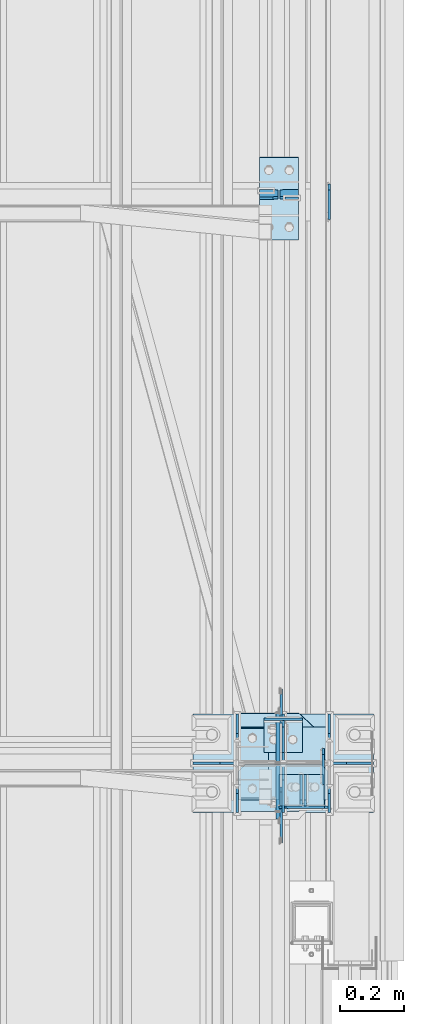
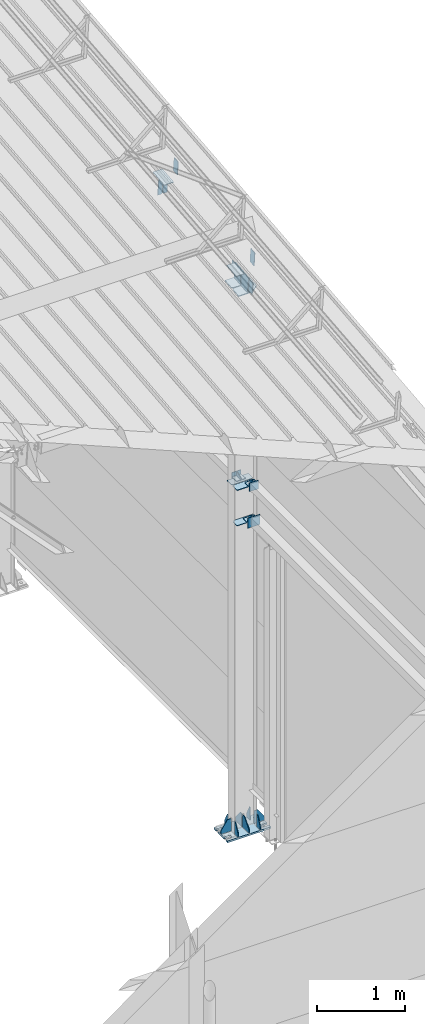
# One storey, part 156 of 709: 33 plates, 4 openings, 8 elements without a shape of their own.
"""IFC4 building model written with IfcOpenShell, lengths in millimetres."""

from ifc_helpers import new_model, si_unit, direction, frame, origin_with_axes, place, context, subcontext, project, spatial, line, arc, indexed_curve, outline, extrude, material, element, aggregate, save


model = new_model("IFC4")

# Units and contexts
model_context = context("Model", 3, precision=0.2, world=origin_with_axes(), true_north=direction((0.0, 1.0)))
body_context = subcontext(model_context, "Body", "Model", "MODEL_VIEW")
ifc_project = project(units=[si_unit("LENGTHUNIT", "METRE", prefix="MILLI"), si_unit("AREAUNIT", "SQUARE_METRE"), si_unit("VOLUMEUNIT", "CUBIC_METRE"), si_unit("MASSUNIT", "GRAM", prefix="KILO"), si_unit("TIMEUNIT", "SECOND"), si_unit("PLANEANGLEUNIT", "RADIAN"), si_unit("SOLIDANGLEUNIT", "STERADIAN"), si_unit("THERMODYNAMICTEMPERATUREUNIT", "DEGREE_CELSIUS"), si_unit("LUMINOUSINTENSITYUNIT", "LUMEN")], contexts=[model_context])

# Site, building, storey
site_placement = place(None, origin_with_axes())
site = spatial("IfcSite", under=ifc_project, at=site_placement, CompositionType="ELEMENT")
building_placement = place(site_placement, origin_with_axes())
building = spatial("IfcBuilding", under=site, at=building_placement, Name="Undefined", CompositionType="ELEMENT")
storey_placement = place(building_placement, origin_with_axes())
storey = spatial("IfcBuildingStorey", under=building, at=storey_placement, Name="Undefined", CompositionType="ELEMENT", Elevation=0.0)

# Assembly, plates, voiding features
assembly_1_placement = place(storey_placement, frame((49851.0, 5500.0, -200.0), z_axis=(0.0, -1.0, 0.0), x_axis=(0.0, 0.0, 1.0)))
assembly_1 = element("IfcElementAssembly", 1, at=assembly_1_placement, inside=storey)
ifc_material = material(Name="C355-6", Category="STEEL")
plate_1_placement = place(assembly_1_placement, frame((4802.0, -140.0, -114.5), z_axis=(-1.0, 0.0, 0.0), x_axis=(0.0, 0.0, 1.0)))
plate_1 = element("IfcPlate", 2, at=plate_1_placement, material=ifc_material, ObjectType="529", context=body_context, shape_type="SolidModel", body=[
    extrude(outline(indexed_curve([(0.0, 0.0), (95.75, 0.0), (110.75, 15.0), (110.75, 265.0), (95.75, 280.0), (0.0, 280.0)], segments=[line(1, 2, 3, 4, 5, 6, 1)])), frame((0.0, 0.0, 4.0), z_axis=(0.0, 0.0, 1.0), x_axis=(1.0, 0.0, 0.0)), (0.0, 0.0, -1.0), 8.0),
])
plate_2_placement = place(assembly_1_placement, frame((4312.0, -140.0, 23.75), z_axis=(1.0, 0.0, 0.0), x_axis=(0.0, 0.7071067812, -0.7071067812)))
plate_2 = element("IfcPlate", 3, at=plate_2_placement, material=ifc_material, Name="PLATE", ObjectType="532", context=body_context, shape_type="SolidModel", body=[
    extrude(outline(indexed_curve([(0.0, 0.0), (28.28427, 0.0), (197.9899, 169.70563), (197.9899, 197.9899), (133.81996, 262.15984), (-64.16994, 64.16994)], segments=[line(1, 2, 3, 4, 5, 6, 1)])), frame((0.0, 0.0, 4.0), z_axis=(0.0, 0.0, 1.0), x_axis=(1.0, 0.0, 0.0)), (0.0, 0.0, -1.0), 8.0),
])
plate_3_placement = place(assembly_1_placement, frame((4802.0, 140.0, 114.5), z_axis=(-1.0, 0.0, 0.0), x_axis=(0.0, 0.0, -1.0)))
plate_3 = element("IfcPlate", 4, at=plate_3_placement, material=ifc_material, ObjectType="505", context=body_context, shape_type="SolidModel", body=[
    extrude(outline(indexed_curve([(0.0, 0.0), (95.75, 0.0), (110.75, 15.0), (110.75, 265.0), (95.75, 280.0), (0.0, 280.0)], segments=[line(1, 2, 3, 4, 5, 6, 1)])), frame((0.0, 0.0, 4.0), z_axis=(0.0, 0.0, 1.0), x_axis=(1.0, 0.0, 0.0)), (0.0, 0.0, -1.0), 8.0),
])
plate_4_placement = place(assembly_1_placement, frame((7533.21454, 17.0, 4.74007), z_axis=(0.0, 1.0, 0.0), x_axis=(-0.099503719, 0.0, 0.9950371902)))
plate_4 = element("IfcPlate", 5, at=plate_4_placement, material=ifc_material, ObjectType="465", context=body_context, shape_type="SolidModel", body=[
    extrude(outline(indexed_curve([(0.0, 0.0), (145.70786, 0.0), (148.29495, 222.12903), (-24.97066, 222.06948)], segments=[line(1, 2, 3, 4, 1)])), frame((0.0, 0.0, 6.0), z_axis=(0.0, 0.0, 1.0), x_axis=(1.0, 0.0, 0.0)), (0.0, 0.0, -1.0), 12.0),
])
plate_5_placement = place(assembly_1_placement, frame((7526.28426, 139.0, 4.34206), z_axis=(0.9950371902, 0.0, 0.099503719), x_axis=(-0.099503719, 0.0, 0.9950371902)))
plate_5 = element("IfcPlate", 6, at=plate_5_placement, material=ifc_material, ObjectType="464", context=body_context, shape_type="SolidModel", body=[
    extrude(outline(indexed_curve([(0.0, 15.0), (15.0, 0.0), (146.70786, 0.0), (146.70786, 187.5), (73.5, 278.0), (15.0, 278.0), (0.0, 263.0)], segments=[line(1, 2, 3, 4, 5, 6, 7, 1)])), frame((0.0, 0.0, 6.0), z_axis=(0.0, 0.0, 1.0), x_axis=(1.0, 0.0, 0.0)), (0.0, 0.0, -1.0), 12.0),
])
plate_6_placement = place(assembly_1_placement, frame((12.5, -284.0, 155.0), z_axis=(1.0, 0.0, 0.0), x_axis=(0.0, 0.0, -1.0)))
plate_6 = element("IfcPlate", 7, at=plate_6_placement, material=ifc_material, ObjectType="425", context=body_context, shape_type="SolidModel", body=[
    extrude(outline(indexed_curve([(0.0, 0.0), (310.0, 0.0), (310.0, 568.0), (0.0, 568.0)], segments=[line(1, 2, 3, 4, 1)])), frame((0.0, 0.0, 12.5), z_axis=(0.0, 0.0, 1.0), x_axis=(1.0, 0.0, 0.0)), (0.0, 0.0, -1.0), 25.0),
])
voiding_feature_1_placement = place(plate_6_placement, frame((40.0, 568.0, 0.0), z_axis=(0.0, 0.0, -1.0), x_axis=(1.0, 0.0, 0.0)))
element("IfcVoidingFeature", 8, at=voiding_feature_1_placement, cuts=plate_6, PredefinedType="HOLE", context=body_context, shape_type="SolidModel", body=[
    extrude(outline(indexed_curve([(0.0, 0.0), (50.0, 0.0), (50.0, 60.0), (42.67767, 77.67767), (25.0, 85.0), (25.0, 85.0), (7.32233, 77.67767), (0.0, 60.0)], segments=[line(1, 2, 3), arc(3, 4, 5), line(5, 6), arc(6, 7, 8), line(8, 1)])), frame((0.0, 0.0, 12.5), z_axis=(0.0, 0.0, 1.0), x_axis=(1.0, 0.0, 0.0)), (0.0, 0.0, -1.0), 25.0),
])
voiding_feature_2_placement = place(plate_6_placement, frame((40.0, 0.0, 0.0), z_axis=(0.0, 0.0, 1.0), x_axis=(1.0, 0.0, 0.0)))
element("IfcVoidingFeature", 9, at=voiding_feature_2_placement, cuts=plate_6, PredefinedType="HOLE", context=body_context, shape_type="SolidModel", body=[
    extrude(outline(indexed_curve([(0.0, 0.0), (50.0, 0.0), (50.0, 60.0), (42.67767, 77.67767), (25.0, 85.0), (25.0, 85.0), (7.32233, 77.67767), (0.0, 60.0)], segments=[line(1, 2, 3), arc(3, 4, 5), line(5, 6), arc(6, 7, 8), line(8, 1)])), frame((0.0, 0.0, 12.5), z_axis=(0.0, 0.0, 1.0), x_axis=(1.0, 0.0, 0.0)), (0.0, 0.0, -1.0), 25.0),
])
voiding_feature_3_placement = place(plate_6_placement, frame((270.0, 568.0, 0.0), z_axis=(0.0, 0.0, 1.0), x_axis=(-1.0, 0.0, 0.0)))
element("IfcVoidingFeature", 10, at=voiding_feature_3_placement, cuts=plate_6, PredefinedType="HOLE", context=body_context, shape_type="SolidModel", body=[
    extrude(outline(indexed_curve([(0.0, 0.0), (50.0, 0.0), (50.0, 60.0), (42.67767, 77.67767), (25.0, 85.0), (25.0, 85.0), (7.32233, 77.67767), (0.0, 60.0)], segments=[line(1, 2, 3), arc(3, 4, 5), line(5, 6), arc(6, 7, 8), line(8, 1)])), frame((0.0, 0.0, 12.5), z_axis=(0.0, 0.0, 1.0), x_axis=(1.0, 0.0, 0.0)), (0.0, 0.0, -1.0), 25.0),
])
voiding_feature_4_placement = place(plate_6_placement, frame((270.0, 0.0, 0.0), z_axis=(0.0, 0.0, -1.0), x_axis=(-1.0, 0.0, 0.0)))
element("IfcVoidingFeature", 11, at=voiding_feature_4_placement, cuts=plate_6, PredefinedType="HOLE", context=body_context, shape_type="SolidModel", body=[
    extrude(outline(indexed_curve([(0.0, 0.0), (50.0, 0.0), (50.0, 60.0), (42.67767, 77.67767), (25.0, 85.0), (25.0, 85.0), (7.32233, 77.67767), (0.0, 60.0)], segments=[line(1, 2, 3), arc(3, 4, 5), line(5, 6), arc(6, 7, 8), line(8, 1)])), frame((0.0, 0.0, 12.5), z_axis=(0.0, 0.0, 1.0), x_axis=(1.0, 0.0, 0.0)), (0.0, 0.0, -1.0), 25.0),
])
plate_7_placement = place(assembly_1_placement, frame((25.0, -149.0, 0.0), z_axis=(0.0, 0.0, 1.0), x_axis=(0.0, -1.0, 0.0)))
plate_7 = element("IfcPlate", 12, at=plate_7_placement, material=ifc_material, ObjectType="418", context=body_context, shape_type="SolidModel", body=[
    extrude(outline(indexed_curve([(0.0, 0.0), (135.0, 0.0), (135.0, 50.0), (50.0, 175.0), (0.0, 175.0)], segments=[line(1, 2, 3, 4, 5, 1)])), frame((0.0, 0.0, 4.0), z_axis=(0.0, 0.0, 1.0), x_axis=(1.0, 0.0, 0.0)), (0.0, 0.0, -1.0), 8.0),
])
plate_8_placement = place(assembly_1_placement, frame((25.0, 0.0, -2.75), z_axis=(0.0, -1.0, 0.0), x_axis=(0.0, 0.0, -1.0)))
plate_8 = element("IfcPlate", 13, at=plate_8_placement, material=ifc_material, ObjectType="417", context=body_context, shape_type="SolidModel", body=[
    extrude(outline(indexed_curve([(0.0, 0.0), (152.25, 0.0), (152.25, 50.0), (50.0, 175.0), (0.0, 175.0)], segments=[line(1, 2, 3, 4, 5, 1)])), frame((0.0, 0.0, 4.0), z_axis=(0.0, 0.0, 1.0), x_axis=(1.0, 0.0, 0.0)), (0.0, 0.0, -1.0), 8.0),
])
plate_9_placement = place(assembly_1_placement, frame((25.0, 145.0, -74.5), z_axis=(0.0, -1.0, 0.0), x_axis=(0.0, 0.0, -1.0)))
plate_9 = element("IfcPlate", 14, at=plate_9_placement, material=ifc_material, ObjectType="426", context=body_context, shape_type="SolidModel", body=[
    extrude(outline(indexed_curve([(0.0, 0.0), (80.5, 0.0), (80.5, 50.0), (20.0, 175.0), (0.0, 175.0)], segments=[line(1, 2, 3, 4, 5, 1)])), frame((0.0, 0.0, 4.0), z_axis=(0.0, 0.0, 1.0), x_axis=(1.0, 0.0, 0.0)), (0.0, 0.0, -1.0), 8.0),
])
plate_10_placement = place(assembly_1_placement, frame((25.0, -145.0, -74.5), z_axis=(0.0, -1.0, 0.0), x_axis=(0.0, 0.0, -1.0)))
plate_10 = element("IfcPlate", 15, at=plate_10_placement, material=ifc_material, ObjectType="426", context=body_context, shape_type="SolidModel", body=[
    extrude(outline(indexed_curve([(0.0, 0.0), (80.5, 0.0), (80.5, 50.0), (20.0, 175.0), (0.0, 175.0)], segments=[line(1, 2, 3, 4, 5, 1)])), frame((0.0, 0.0, 4.0), z_axis=(0.0, 0.0, 1.0), x_axis=(1.0, 0.0, 0.0)), (0.0, 0.0, -1.0), 8.0),
])
plate_11_placement = place(assembly_1_placement, frame((25.0, 145.0, 74.5), z_axis=(0.0, 1.0, 0.0), x_axis=(0.0, 0.0, 1.0)))
plate_11 = element("IfcPlate", 16, at=plate_11_placement, material=ifc_material, ObjectType="426", context=body_context, shape_type="SolidModel", body=[
    extrude(outline(indexed_curve([(0.0, 0.0), (80.5, 0.0), (80.5, 50.0), (20.0, 175.0), (0.0, 175.0)], segments=[line(1, 2, 3, 4, 5, 1)])), frame((0.0, 0.0, 4.0), z_axis=(0.0, 0.0, 1.0), x_axis=(1.0, 0.0, 0.0)), (0.0, 0.0, -1.0), 8.0),
])
plate_12_placement = place(assembly_1_placement, frame((25.0, 0.0, 2.75), z_axis=(0.0, 1.0, 0.0), x_axis=(0.0, 0.0, 1.0)))
plate_12 = element("IfcPlate", 17, at=plate_12_placement, material=ifc_material, ObjectType="417", context=body_context, shape_type="SolidModel", body=[
    extrude(outline(indexed_curve([(0.0, 0.0), (152.25, 0.0), (152.25, 50.0), (50.0, 175.0), (0.0, 175.0)], segments=[line(1, 2, 3, 4, 5, 1)])), frame((0.0, 0.0, 4.0), z_axis=(0.0, 0.0, 1.0), x_axis=(1.0, 0.0, 0.0)), (0.0, 0.0, -1.0), 8.0),
])
plate_13_placement = place(assembly_1_placement, frame((25.0, 149.0, 0.0), z_axis=(0.0, 0.0, -1.0), x_axis=(0.0, 1.0, 0.0)))
plate_13 = element("IfcPlate", 18, at=plate_13_placement, material=ifc_material, ObjectType="418", context=body_context, shape_type="SolidModel", body=[
    extrude(outline(indexed_curve([(0.0, 0.0), (135.0, 0.0), (135.0, 50.0), (50.0, 175.0), (0.0, 175.0)], segments=[line(1, 2, 3, 4, 5, 1)])), frame((0.0, 0.0, 4.0), z_axis=(0.0, 0.0, 1.0), x_axis=(1.0, 0.0, 0.0)), (0.0, 0.0, -1.0), 8.0),
])
plate_14_placement = place(assembly_1_placement, frame((25.0, -145.0, 74.5), z_axis=(0.0, 1.0, 0.0), x_axis=(0.0, 0.0, 1.0)))
plate_14 = element("IfcPlate", 19, at=plate_14_placement, material=ifc_material, ObjectType="426", context=body_context, shape_type="SolidModel", body=[
    extrude(outline(indexed_curve([(0.0, 0.0), (80.5, 0.0), (80.5, 50.0), (20.0, 175.0), (0.0, 175.0)], segments=[line(1, 2, 3, 4, 5, 1)])), frame((0.0, 0.0, 4.0), z_axis=(0.0, 0.0, 1.0), x_axis=(1.0, 0.0, 0.0)), (0.0, 0.0, -1.0), 8.0),
])
plate_15_placement = place(assembly_1_placement, frame((7533.96354, 17.0, -2.75), z_axis=(0.0, -1.0, 0.0), x_axis=(0.099503719, 0.0, -0.9950371902)))
plate_15 = element("IfcPlate", 20, at=plate_15_placement, material=ifc_material, ObjectType="468", context=body_context, shape_type="SolidModel", body=[
    extrude(outline(indexed_curve([(0.0, 0.0), (156.50786, 0.0), (153.92076, 222.12903), (21.44323, 222.06948)], segments=[line(1, 2, 3, 4, 1)])), frame((0.0, 0.0, 6.0), z_axis=(0.0, 0.0, 1.0), x_axis=(1.0, 0.0, 0.0)), (0.0, 0.0, -1.0), 12.0),
])
plate_16_placement = place(assembly_1_placement, frame((7527.03327, 139.0, -3.14801), z_axis=(-0.9950371902, 0.0, -0.099503719), x_axis=(0.099503719, 0.0, -0.9950371902)))
plate_16 = element("IfcPlate", 21, at=plate_16_placement, material=ifc_material, ObjectType="467", context=body_context, shape_type="SolidModel", body=[
    extrude(outline(indexed_curve([(-0.10791, 14.99961), (15.0, 0.0), (155.50786, 0.0), (155.50786, 187.5), (71.5, 278.0), (13.0, 278.0), (-1.89209, 263.00039)], segments=[line(1, 2, 3, 4, 5, 6, 7, 1)])), frame((0.0, 0.0, 6.0), z_axis=(0.0, 0.0, 1.0), x_axis=(1.0, 0.0, 0.0)), (0.0, 0.0, -1.0), 12.0),
])
aggregate(assembly_1, [plate_1, plate_2, plate_3, plate_4, plate_5, plate_6, plate_7, plate_8, plate_9, plate_10, plate_11, plate_12, plate_13, plate_14, plate_15, plate_16])

# Assembly, plate
assembly_2_placement = place(storey_placement, frame((49837.5, 346.0, 6929.907), z_axis=(1.0, 0.0, 0.0), x_axis=(0.0, 0.9950371902, 0.099503719)))
assembly_2 = element("IfcElementAssembly", 22, at=assembly_2_placement, inside=storey)
plate_17_placement = place(assembly_2_placement, frame((5096.83432, -80.0, 6.5), z_axis=(0.0, 0.0, 1.0), x_axis=(0.0, 1.0, 0.0)))
plate_17 = element("IfcPlate", 23, at=plate_17_placement, material=ifc_material, ObjectType="463", context=body_context, shape_type="SolidModel", body=[
    extrude(outline(indexed_curve([(0.0, 0.0), (160.0, 0.0), (160.0, 160.0), (0.0, 160.0)], segments=[line(1, 2, 3, 4, 1)])), frame((0.0, 0.0, 4.0), z_axis=(0.0, 0.0, 1.0), x_axis=(1.0, 0.0, 0.0)), (0.0, 0.0, -1.0), 8.0),
])
aggregate(assembly_2, [plate_17])

# Assembly, plates
assembly_3_placement = place(storey_placement, frame((49837.5, 5500.0, 7445.307), z_axis=(1.0, 0.0, 0.0), x_axis=(0.0, 0.9950371902, 0.099503719)))
assembly_3 = element("IfcElementAssembly", 24, at=assembly_3_placement, inside=storey)
plate_18_placement = place(assembly_3_placement, frame((1795.34469, 115.0, 62.0), z_axis=(-1.0, 0.0, 0.0), x_axis=(0.0, 0.0, -1.0)))
plate_18 = element("IfcPlate", 25, at=plate_18_placement, material=ifc_material, ObjectType="594", context=body_context, shape_type="SolidModel", body=[
    extrude(outline(indexed_curve([(0.0, 0.0), (43.5, 0.0), (58.5, 15.0), (58.5, 215.0), (43.5, 230.0), (0.0, 230.0)], segments=[line(1, 2, 3, 4, 5, 6, 1)])), frame((0.0, 0.0, 4.0), z_axis=(0.0, 0.0, 1.0), x_axis=(1.0, 0.0, 0.0)), (0.0, 0.0, -1.0), 8.0),
])
plate_19_placement = place(assembly_3_placement, frame((1795.34469, -115.0, -62.0), z_axis=(-1.0, 0.0, 0.0), x_axis=(0.0, 0.0, 1.0)))
plate_19 = element("IfcPlate", 26, at=plate_19_placement, material=ifc_material, ObjectType="594", context=body_context, shape_type="SolidModel", body=[
    extrude(outline(indexed_curve([(0.0, 0.0), (43.5, 0.0), (58.5, 15.0), (58.5, 215.0), (43.5, 230.0), (0.0, 230.0)], segments=[line(1, 2, 3, 4, 5, 6, 1)])), frame((0.0, 0.0, 4.0), z_axis=(0.0, 0.0, 1.0), x_axis=(1.0, 0.0, 0.0)), (0.0, 0.0, -1.0), 8.0),
])
plate_20_placement = place(assembly_3_placement, frame((66.87157, -80.0, 6.5), z_axis=(0.0, 0.0, -1.0), x_axis=(0.0, 1.0, 0.0)))
plate_20 = element("IfcPlate", 27, at=plate_20_placement, material=ifc_material, ObjectType="463", context=body_context, shape_type="SolidModel", body=[
    extrude(outline(indexed_curve([(0.0, 0.0), (160.0, 0.0), (160.0, 160.0), (0.0, 160.0)], segments=[line(1, 2, 3, 4, 1)])), frame((0.0, 0.0, 4.0), z_axis=(0.0, 0.0, 1.0), x_axis=(1.0, 0.0, 0.0)), (0.0, 0.0, -1.0), 8.0),
])
aggregate(assembly_3, [plate_18, plate_19, plate_20])

assembly_4_placement = place(storey_placement, frame((49920.0, 80.0, 4610.0), z_axis=(0.0, 0.0, -1.0), x_axis=(0.0, 1.0, 0.0)))
assembly_4 = element("IfcElementAssembly", 28, at=assembly_4_placement, inside=storey)
plate_21_placement = place(assembly_4_placement, frame((5281.5, -60.0, 60.0), z_axis=(1.0, 0.0, 0.0), x_axis=(0.0, 0.0, -1.0)))
plate_21 = element("IfcPlate", 29, at=plate_21_placement, material=ifc_material, ObjectType="506", context=body_context, shape_type="SolidModel", body=[
    extrude(outline(indexed_curve([(0.0, 0.0), (120.0, 0.0), (120.0, 120.0), (0.0, 120.0)], segments=[line(1, 2, 3, 4, 1)])), frame((0.0, 0.0, 4.0), z_axis=(0.0, 0.0, 1.0), x_axis=(1.0, 0.0, 0.0)), (0.0, 0.0, -1.0), 8.0),
])
plate_22_placement = place(assembly_4_placement, frame((5385.5, -60.0, 0.0), z_axis=(0.0, 0.0, 1.0), x_axis=(0.0, 1.0, 0.0)))
plate_22 = element("IfcPlate", 30, at=plate_22_placement, material=ifc_material, ObjectType="507", context=body_context, shape_type="SolidModel", body=[
    extrude(outline(indexed_curve([(0.0, 0.0), (120.0, 0.0), (120.0, 100.0), (0.0, 100.0)], segments=[line(1, 2, 3, 4, 1)])), frame((0.0, 0.0, 4.0), z_axis=(0.0, 0.0, 1.0), x_axis=(1.0, 0.0, 0.0)), (0.0, 0.0, -1.0), 8.0),
])
plate_23_placement = place(assembly_4_placement, frame((5385.5, 0.0, -60.0), z_axis=(0.0, -1.0, 0.0), x_axis=(0.0, 0.0, 1.0)))
plate_23 = element("IfcPlate", 31, at=plate_23_placement, material=ifc_material, ObjectType="508", context=body_context, shape_type="SolidModel", body=[
    extrude(outline(indexed_curve([(0.0, 80.0), (36.0, 0.0), (56.0, 0.0), (56.0, 90.0), (46.0, 100.0), (0.0, 100.0)], segments=[line(1, 2, 3, 4, 5, 6, 1)])), frame((0.0, 0.0, 4.0), z_axis=(0.0, 0.0, 1.0), x_axis=(1.0, 0.0, 0.0)), (0.0, 0.0, -1.0), 8.0),
])
aggregate(assembly_4, [plate_21, plate_22, plate_23])

assembly_5_placement = place(storey_placement, frame((49940.0, 80.0, 4120.0), z_axis=(0.0, 0.0, -1.0), x_axis=(0.0, 1.0, 0.0)))
assembly_5 = element("IfcElementAssembly", 32, at=assembly_5_placement, inside=storey)
plate_24_placement = place(assembly_5_placement, frame((5385.5, -103.0, 0.0), z_axis=(0.0, 0.0, -1.0), x_axis=(-1.0, 0.0, 0.0)))
plate_24 = element("IfcPlate", 33, at=plate_24_placement, material=ifc_material, ObjectType="534", context=body_context, shape_type="SolidModel", body=[
    extrude(outline(indexed_curve([(0.0, 0.0), (100.0, 0.0), (100.0, 140.0), (0.0, 140.0)], segments=[line(1, 2, 3, 4, 1)])), frame((0.0, 0.0, 4.0), z_axis=(0.0, 0.0, 1.0), x_axis=(1.0, 0.0, 0.0)), (0.0, 0.0, -1.0), 8.0),
])
plate_25_placement = place(assembly_5_placement, frame((5281.5, -103.0, -70.0), z_axis=(1.0, 0.0, 0.0), x_axis=(0.0, 1.0, 0.0)))
plate_25 = element("IfcPlate", 34, at=plate_25_placement, material=ifc_material, ObjectType="533", context=body_context, shape_type="SolidModel", body=[
    extrude(outline(indexed_curve([(0.0, 0.0), (161.0, 0.0), (161.0, 140.0), (0.0, 140.0)], segments=[line(1, 2, 3, 4, 1)])), frame((0.0, 0.0, 4.0), z_axis=(0.0, 0.0, 1.0), x_axis=(1.0, 0.0, 0.0)), (0.0, 0.0, -1.0), 8.0),
])
plate_26_placement = place(assembly_5_placement, frame((5385.5, -33.0, -70.0), z_axis=(0.0, 1.0, 0.0), x_axis=(-1.0, 0.0, 0.0)))
plate_26 = element("IfcPlate", 35, at=plate_26_placement, material=ifc_material, ObjectType="535", context=body_context, shape_type="SolidModel", body=[
    extrude(outline(indexed_curve([(0.0, 50.0), (80.0, 0.0), (100.0, 0.0), (100.0, 70.0), (0.0, 70.0)], segments=[line(1, 2, 3, 4, 5, 1)])), frame((0.0, 0.0, 4.0), z_axis=(0.0, 0.0, 1.0), x_axis=(1.0, 0.0, 0.0)), (0.0, 0.0, -1.0), 8.0),
])
aggregate(assembly_5, [plate_24, plate_25, plate_26])

assembly_6_placement = place(storey_placement, frame((49851.0, 5500.0, 4610.0), z_axis=(0.0, 0.0, -1.0), x_axis=(0.0, 1.0, 0.0)))
assembly_6 = element("IfcElementAssembly", 36, at=assembly_6_placement, inside=storey)
plate_27_placement = place(assembly_6_placement, frame((34.5, 60.0, 0.0), z_axis=(0.0, 0.0, 1.0), x_axis=(0.0, -1.0, 0.0)))
plate_27 = element("IfcPlate", 37, at=plate_27_placement, material=ifc_material, ObjectType="507", context=body_context, shape_type="SolidModel", body=[
    extrude(outline(indexed_curve([(0.0, 0.0), (120.0, 0.0), (120.0, 100.0), (0.0, 100.0)], segments=[line(1, 2, 3, 4, 1)])), frame((0.0, 0.0, 4.0), z_axis=(0.0, 0.0, 1.0), x_axis=(1.0, 0.0, 0.0)), (0.0, 0.0, -1.0), 8.0),
])
plate_28_placement = place(assembly_6_placement, frame((34.5, 0.0, -60.0), z_axis=(0.0, 1.0, 0.0), x_axis=(0.0, 0.0, 1.0)))
plate_28 = element("IfcPlate", 38, at=plate_28_placement, material=ifc_material, ObjectType="508", context=body_context, shape_type="SolidModel", body=[
    extrude(outline(indexed_curve([(0.0, 80.0), (36.0, 0.0), (56.0, 0.0), (56.0, 90.0), (46.0, 100.0), (0.0, 100.0)], segments=[line(1, 2, 3, 4, 5, 6, 1)])), frame((0.0, 0.0, 4.0), z_axis=(0.0, 0.0, 1.0), x_axis=(1.0, 0.0, 0.0)), (0.0, 0.0, -1.0), 8.0),
])
plate_29_placement = place(assembly_6_placement, frame((138.5, 60.0, 60.0), z_axis=(-1.0, 0.0, 0.0), x_axis=(0.0, 0.0, -1.0)))
plate_29 = element("IfcPlate", 39, at=plate_29_placement, material=ifc_material, ObjectType="506", context=body_context, shape_type="SolidModel", body=[
    extrude(outline(indexed_curve([(0.0, 0.0), (120.0, 0.0), (120.0, 120.0), (0.0, 120.0)], segments=[line(1, 2, 3, 4, 1)])), frame((0.0, 0.0, 4.0), z_axis=(0.0, 0.0, 1.0), x_axis=(1.0, 0.0, 0.0)), (0.0, 0.0, -1.0), 8.0),
])
aggregate(assembly_6, [plate_27, plate_28, plate_29])

assembly_7_placement = place(storey_placement, frame((46000.0, 5490.04963, 7677.46908), z_axis=(0.0, 0.9950371902, 0.099503719), x_axis=(1.0, 0.0, 0.0)))
assembly_7 = element("IfcElementAssembly", 40, at=assembly_7_placement, inside=storey)
plate_30_placement = place(assembly_7_placement, frame((3976.0, -97.0, 47.0), z_axis=(1.0, 0.0, 0.0), x_axis=(0.0, 0.0, -1.0)))
plate_30 = element("IfcPlate", 41, at=plate_30_placement, material=ifc_material, ObjectType="592", context=body_context, shape_type="SolidModel", body=[
    extrude(outline(indexed_curve([(0.0, 0.0), (94.0, 0.0), (94.0, 194.0), (0.0, 194.0)], segments=[line(1, 2, 3, 4, 1)])), frame((0.0, 0.0, 4.0), z_axis=(0.0, 0.0, 1.0), x_axis=(1.0, 0.0, 0.0)), (0.0, 0.0, -1.0), 8.0),
])
plate_31_placement = place(assembly_7_placement, frame((3804.0, 103.94045, 110.0), z_axis=(0.0, -1.0, 0.0), x_axis=(-1.0, 0.0, 0.0)))
plate_31 = element("IfcPlate", 42, at=plate_31_placement, material=ifc_material, ObjectType="591", context=body_context, shape_type="SolidModel", body=[
    extrude(outline(indexed_curve([(0.0, 0.0), (100.0, 0.0), (100.0, 220.0), (0.0, 220.0)], segments=[line(1, 2, 3, 4, 1)])), frame((0.0, 0.0, 4.0), z_axis=(0.0, 0.0, 1.0), x_axis=(1.0, 0.0, 0.0)), (0.0, 0.0, -1.0), 8.0),
])
aggregate(assembly_7, [plate_30, plate_31])

assembly_8_placement = place(storey_placement, frame((46000.0, 7263.34988, 7854.7991), z_axis=(0.0, 0.9950371902, 0.099503719), x_axis=(1.0, 0.0, 0.0)))
assembly_8 = element("IfcElementAssembly", 43, at=assembly_8_placement, inside=storey)
plate_32_placement = place(assembly_8_placement, frame((3996.0, -97.0, 47.0), z_axis=(1.0, 0.0, 0.0), x_axis=(0.0, 0.0, -1.0)))
plate_32 = element("IfcPlate", 44, at=plate_32_placement, material=ifc_material, ObjectType="592", context=body_context, shape_type="SolidModel", body=[
    extrude(outline(indexed_curve([(0.0, 0.0), (94.0, 0.0), (94.0, 194.0), (0.0, 194.0)], segments=[line(1, 2, 3, 4, 1)])), frame((0.0, 0.0, 4.0), z_axis=(0.0, 0.0, 1.0), x_axis=(1.0, 0.0, 0.0)), (0.0, 0.0, -1.0), 8.0),
])
plate_33_placement = place(assembly_8_placement, frame((3775.5, 104.0, -130.0), z_axis=(0.0, 1.0, 0.0), x_axis=(0.0, 0.0, 1.0)))
plate_33 = element("IfcPlate", 45, at=plate_33_placement, material=ifc_material, ObjectType="593", context=body_context, shape_type="SolidModel", body=[
    extrude(outline(indexed_curve([(0.0, 0.0), (260.0, 0.0), (260.0, 124.0), (0.0, 124.0)], segments=[line(1, 2, 3, 4, 1)])), frame((0.0, 0.0, 4.0), z_axis=(0.0, 0.0, 1.0), x_axis=(1.0, 0.0, 0.0)), (0.0, 0.0, -1.0), 8.0),
])
aggregate(assembly_8, [plate_32, plate_33])

save(model, "model.ifc")
